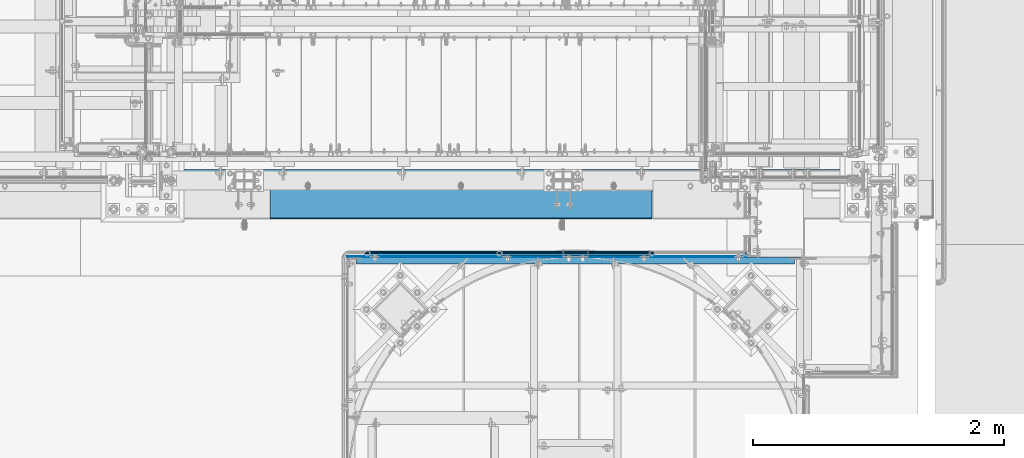
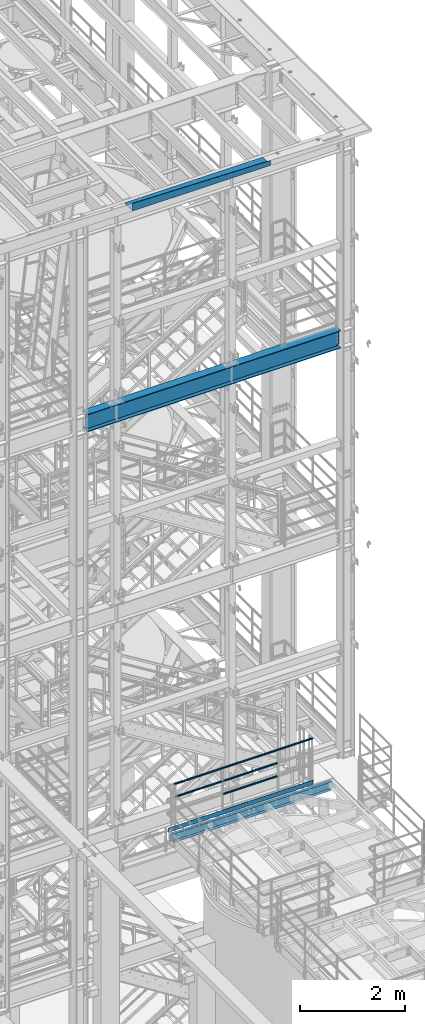
# One storey, part 944 of 1876: 8 beams, 4 elements without a shape of their own.
"""IFC2X3 building model written with IfcOpenShell, lengths in millimetres."""

from ifc_helpers import new_model, si_unit, frame, origin_with_axes, place, context, subcontext, project, spatial, faceted_brep, material, type_object, element, aggregate, save


model = new_model("IFC2X3")

# Units and contexts
model_context = context("Model", 3, precision=1e-05, world=origin_with_axes())
body_context = subcontext(model_context, "Body", "Model", "MODEL_VIEW")
ifc_project = project(units=[si_unit("LENGTHUNIT", "METRE", prefix="MILLI"), si_unit("AREAUNIT", "SQUARE_METRE"), si_unit("VOLUMEUNIT", "CUBIC_METRE"), si_unit("MASSUNIT", "GRAM", prefix="KILO"), si_unit("TIMEUNIT", "SECOND"), si_unit("PLANEANGLEUNIT", "RADIAN"), si_unit("SOLIDANGLEUNIT", "STERADIAN"), si_unit("THERMODYNAMICTEMPERATUREUNIT", "DEGREE_CELSIUS"), si_unit("LUMINOUSINTENSITYUNIT", "LUMEN")], contexts=[model_context])

# Site, building, storey
site_placement = place(None, origin_with_axes())
site = spatial("IfcSite", under=ifc_project, at=site_placement, CompositionType="ELEMENT")
building_placement = place(site_placement, origin_with_axes())
building = spatial("IfcBuilding", under=site, at=building_placement, Name="Undefined", CompositionType="ELEMENT")
storey_placement = place(building_placement, origin_with_axes())
storey = spatial("IfcBuildingStorey", under=building, at=storey_placement, Name="Undefined", CompositionType="ELEMENT", Elevation=0.0)

# Assembly, beams
assembly_1_placement = place(storey_placement, origin_with_axes())
assembly_1 = element("IfcElementAssembly", 1, at=assembly_1_placement, inside=storey, Name="HANDRAIL", AssemblyPlace="NOTDEFINED", PredefinedType="RIGID_FRAME")
ifc_material_1 = material()
beam_type_1 = type_object("IfcBeamType", Name="PIPE1-1/4STD", PredefinedType="NOTDEFINED")
beam_1_placement = place(assembly_1_placement, frame((4572.00474593762, -7694.13240429563, 8480.425), z_axis=(0.0, 0.0, 1.0), x_axis=(1.0, 0.0, 0.0)))
beam_1 = element("IfcBeam", 2, at=beam_1_placement, type_object=beam_type_1, material=ifc_material_1, Name="RAIL", ObjectType="PIPE1-1/4STD", context=body_context, shape_type="Brep", body=[
    faceted_brep([(1200.94245243742, -10.5409999999993, 18.2575475625836), (1200.94245243742, -10.5409999999993, 13.3999612267253), (1200.46603877327, -8.76300000000083, 15.1779612267255), (1198.118, 0.0, 17.5259999999998), (1198.118, 0.0, 21.0820000000003), (1200.46603877327, 8.76300000000083, 15.1779612267255), (1200.94245243742, 10.5409999999993, 13.3999612267253), (1200.94245243742, 10.5409999999993, 18.2575475625836), (1219.2, 21.0820000000003, 0.0), (1208.659, 18.2575475625836, 10.5409999999993), (1208.659, 18.2575475625836, -10.5409999999993), (1205.57941366414, 15.1779612267255, 8.76300000000083), (1207.92745243742, 17.5259999999998, 0.0), (1205.57941366414, 15.1779612267255, -8.76300000000083), (1200.94245243742, 10.5409999999993, -13.3999612267253), (1200.94245243742, 10.5409999999993, -18.2575475625836), (1200.46603877327, 8.76300000000083, -15.1779612267255), (1198.118, 0.0, -17.5259999999998), (1198.118, 0.0, -21.0820000000003), (1200.94245243742, -10.5409999999993, -13.3999612267253), (1200.94245243742, -10.5409999999993, -18.2575475625836), (1200.46603877327, -8.76300000000083, -15.1779612267255), (1219.2, -21.0820000000003, 0.0), (1208.659, -18.2575475625836, -10.5409999999993), (1208.659, -18.2575475625836, 10.5409999999993), (1205.57941366414, -15.1779612267255, -8.76300000000083), (1207.92745243742, -17.5259999999998, 0.0), (1205.57941366414, -15.1779612267255, 8.76300000000083), (10.5409999957128, -18.2575475672238, -10.5409999999993), (18.2575475625817, -10.5410000000011, -18.2575475625836), (9.09494701772928e-13, 21.0820000000003, 0.0), (10.5409999957128, 18.2575475579433, -10.5409999999993), (10.5409999999983, 18.2575475625836, 10.5410000000011), (18.2575475625817, 10.5409999999993, 18.2575475625836), (21.0819999999985, 1.81898940354586e-12, 21.0820000000003), (18.2575475625817, 10.5409999999993, -18.2575475625836), (21.0819999999985, 0.0, -21.0819999999985), (21.0819999999985, 0.0, -17.5259999999998), (18.2575475625817, -10.5409999999974, -13.3999612267271), (18.7339612267233, -8.76300000000083, -15.1779612267255), (18.7339612267251, 8.76299999999901, -15.1779612267255), (18.2575475625817, 10.5410000000011, -13.3999612267235), (13.6205863358573, 15.1779612267255, -8.76299999999901), (11.2725475625839, 17.5259999999998, 0.0), (13.6205863358573, 15.1779612267255, 8.76300000000083), (18.2575475625817, 10.5410000000011, 13.3999612267253), (18.7339612267251, 8.76299999999901, 15.1779612267273), (21.0819999999985, 1.81898940354586e-12, 17.5259999999998), (18.7339612267233, -8.76300000000083, 15.1779612267273), (18.2575475625817, -10.5409999999974, 13.3999612267289), (18.2575475625817, -10.5410000000011, 18.2575475625836), (10.5409999999983, -18.2575475625836, 10.5410000000011), (9.09494701772928e-13, -21.0820000000003, 0.0), (13.6205863358537, -15.1779612267255, 8.76300000000083), (11.2725475625793, -17.5259999999998, 0.0), (13.6205863358537, -15.1779612267255, -8.76299999999901)], [[[0, 1, 2, 3, 4]], [[4, 3, 5, 6, 7]], [[8, 9, 10]], [[7, 6, 11, 12, 13, 14, 15, 10, 9]], [[16, 17, 18, 15, 14]], [[19, 20, 18, 17, 21]], [[22, 23, 24]], [[24, 23, 20, 19, 25, 26, 27, 1, 0]], [[28, 29, 20, 23]], [[30, 31, 32]], [[33, 34, 4, 7]], [[32, 33, 7, 9]], [[30, 32, 9, 8]], [[31, 30, 8, 10]], [[35, 31, 10, 15]], [[36, 35, 15, 18]], [[29, 36, 18, 20]], [[37, 36, 29, 38, 39]], [[40, 41, 35, 36, 37]], [[32, 31, 35, 41, 42, 43, 44, 45, 33]], [[33, 45, 46, 47, 34]], [[34, 47, 48, 49, 50]], [[34, 50, 0, 4]], [[50, 51, 24, 0]], [[51, 52, 22, 24]], [[52, 28, 23, 22]], [[51, 28, 52]], [[50, 49, 53, 54, 55, 38, 29, 28, 51]], [[55, 54, 26, 25]], [[21, 39, 38, 55, 25, 19]], [[37, 39, 21, 17]], [[40, 37, 17, 16]], [[42, 41, 40, 16, 14, 13]], [[43, 42, 13, 12]], [[44, 43, 12, 11]], [[5, 46, 45, 44, 11, 6]], [[47, 46, 5, 3]], [[48, 47, 3, 2]], [[53, 49, 48, 2, 1, 27]], [[54, 53, 27, 26]]]),
])
beam_2_placement = place(assembly_1_placement, frame((5791.20474593762, -7694.13240429563, 8785.225), z_axis=(0.0, 0.0, -1.0), x_axis=(-1.0, 0.0, 0.0)))
beam_2 = element("IfcBeam", 3, at=beam_2_placement, type_object=beam_type_1, material=ifc_material_1, Name="RAIL", ObjectType="PIPE1-1/4STD", context=body_context, shape_type="Brep", body=[
    faceted_brep([(9.09494701772928e-13, 21.0820000000003, 0.0), (10.5409999957128, 18.2575475579433, -10.5409999999993), (10.5409999999983, 18.2575475625836, 10.5410000000011), (10.5409999999983, -18.2575475625836, 10.5410000000011), (10.5409999957128, -18.2575475672238, -10.5409999999993), (9.09494701772928e-13, -21.0820000000003, 0.0), (18.2575475625817, -10.5410000000011, 18.2575475625836), (18.2575475625817, -10.5409999999974, 13.3999612267289), (13.6205863358537, -15.1779612267255, 8.76300000000083), (11.2725475625793, -17.5259999999998, 0.0), (13.6205863358537, -15.1779612267255, -8.76299999999901), (18.2575475625817, -10.5409999999974, -13.3999612267271), (18.2575475625817, -10.5410000000011, -18.2575475625836), (21.0819999999985, 0.0, -17.5259999999998), (21.0819999999985, 0.0, -21.0819999999985), (18.7339612267233, -8.76300000000083, -15.1779612267255), (18.7339612267251, 8.76299999999901, -15.1779612267255), (18.2575475625817, 10.5410000000011, -13.3999612267235), (18.2575475625817, 10.5409999999993, -18.2575475625836), (13.6205863358573, 15.1779612267255, -8.76299999999901), (11.2725475625839, 17.5259999999998, 0.0), (13.6205863358573, 15.1779612267255, 8.76300000000083), (18.2575475625817, 10.5410000000011, 13.3999612267253), (18.2575475625817, 10.5409999999993, 18.2575475625836), (18.7339612267251, 8.76299999999901, 15.1779612267273), (21.0819999999985, 1.81898940354586e-12, 17.5259999999998), (21.0819999999985, 1.81898940354586e-12, 21.0820000000003), (18.7339612267233, -8.76300000000083, 15.1779612267273), (1219.2, 21.0820000000003, 0.0), (1208.659, 18.2575475625836, -10.5409999999993), (1200.94245243742, 10.5409999999993, -18.2575475625836), (1219.2, -21.0820000000003, 0.0), (1208.659, -18.2575475625836, -10.5409999999993), (1208.659, -18.2575475625836, 10.5409999999993), (1200.94245243742, -10.5409999999993, 18.2575475625836), (1200.94245243742, -10.5409999999993, -18.2575475625836), (1198.118, 0.0, -21.0820000000003), (1200.46603877327, 8.76300000000083, -15.1779612267255), (1198.118, 0.0, -17.5259999999998), (1200.94245243742, 10.5409999999993, -13.3999612267253), (1200.94245243742, -10.5409999999993, -13.3999612267253), (1200.46603877327, -8.76300000000083, -15.1779612267255), (1205.57941366414, -15.1779612267255, -8.76300000000083), (1207.92745243742, -17.5259999999998, 0.0), (1205.57941366414, -15.1779612267255, 8.76300000000083), (1200.94245243742, -10.5409999999993, 13.3999612267253), (1200.46603877327, -8.76300000000083, 15.1779612267255), (1198.118, 0.0, 17.5259999999998), (1198.118, 0.0, 21.0820000000003), (1200.94245243742, 10.5409999999993, 18.2575475625836), (1208.659, 18.2575475625836, 10.5409999999993), (1200.94245243742, 10.5409999999993, 13.3999612267253), (1205.57941366414, 15.1779612267255, 8.76300000000083), (1207.92745243742, 17.5259999999998, 0.0), (1205.57941366414, 15.1779612267255, -8.76300000000083), (1200.46603877327, 8.76300000000083, 15.1779612267255)], [[[0, 1, 2]], [[3, 4, 5]], [[6, 7, 8, 9, 10, 11, 12, 4, 3]], [[13, 14, 12, 11, 15]], [[16, 17, 18, 14, 13]], [[2, 1, 18, 17, 19, 20, 21, 22, 23]], [[23, 22, 24, 25, 26]], [[26, 25, 27, 7, 6]], [[1, 0, 28, 29]], [[18, 1, 29, 30]], [[31, 32, 33]], [[6, 3, 33, 34]], [[3, 5, 31, 33]], [[5, 4, 32, 31]], [[4, 12, 35, 32]], [[12, 14, 36, 35]], [[14, 18, 30, 36]], [[37, 38, 36, 30, 39]], [[40, 35, 36, 38, 41]], [[33, 32, 35, 40, 42, 43, 44, 45, 34]], [[34, 45, 46, 47, 48]], [[26, 6, 34, 48]], [[2, 23, 49, 50]], [[23, 26, 48, 49]], [[0, 2, 50, 28]], [[28, 50, 29]], [[49, 51, 52, 53, 54, 39, 30, 29, 50]], [[48, 47, 55, 51, 49]], [[25, 24, 55, 47]], [[55, 24, 22, 21, 52, 51]], [[21, 20, 53, 52]], [[20, 19, 54, 53]], [[19, 17, 16, 37, 39, 54]], [[16, 13, 38, 37]], [[13, 15, 41, 38]], [[41, 15, 11, 10, 42, 40]], [[10, 9, 43, 42]], [[9, 8, 44, 43]], [[8, 7, 27, 46, 45, 44]], [[27, 25, 47, 46]]]),
])
beam_3_placement = place(assembly_1_placement, frame((4572.00474593762, -7694.13240429563, 8785.225), z_axis=(0.0, 0.0, -1.0), x_axis=(-1.0, 0.0, 0.0)))
beam_3 = element("IfcBeam", 4, at=beam_3_placement, type_object=beam_type_1, material=ifc_material_1, Name="RAIL", ObjectType="PIPE1-1/4STD", context=body_context, shape_type="Brep", body=[
    faceted_brep([(9.09494701772928e-13, 21.0820000000003, 0.0), (10.5409999957128, 18.2575475579433, -10.5409999999993), (10.5409999999983, 18.2575475625836, 10.5410000000011), (10.5409999999983, -18.2575475625836, 10.5410000000011), (10.5409999957128, -18.2575475672238, -10.5409999999993), (9.09494701772928e-13, -21.0820000000003, 0.0), (18.2575475625817, -10.5410000000011, 18.2575475625836), (18.2575475625817, -10.5409999999974, 13.3999612267289), (13.6205863358537, -15.1779612267255, 8.76300000000083), (11.2725475625793, -17.5259999999998, 0.0), (13.6205863358537, -15.1779612267255, -8.76299999999901), (18.2575475625817, -10.5409999999974, -13.3999612267271), (18.2575475625817, -10.5410000000011, -18.2575475625836), (21.0819999999985, 0.0, -17.5259999999998), (21.0819999999985, 0.0, -21.0819999999985), (18.7339612267233, -8.76300000000083, -15.1779612267255), (18.7339612267251, 8.76299999999901, -15.1779612267255), (18.2575475625817, 10.5410000000011, -13.3999612267235), (18.2575475625817, 10.5409999999993, -18.2575475625836), (13.6205863358573, 15.1779612267255, -8.76299999999901), (11.2725475625839, 17.5259999999998, 0.0), (13.6205863358573, 15.1779612267255, 8.76300000000083), (18.2575475625817, 10.5410000000011, 13.3999612267253), (18.2575475625817, 10.5409999999993, 18.2575475625836), (18.7339612267251, 8.76299999999901, 15.1779612267273), (21.0819999999985, 1.81898940354586e-12, 17.5259999999998), (21.0819999999985, 1.81898940354586e-12, 21.0820000000003), (18.7339612267233, -8.76300000000083, 15.1779612267273), (1054.1, 21.0820000000003, 0.0), (1043.559, 18.2575475625836, -10.5409999999993), (1035.84245243742, 10.5409999999993, -18.2575475625836), (1054.1, -21.0820000000003, 0.0), (1043.559, -18.2575475625836, -10.5409999999993), (1043.559, -18.2575475625836, 10.5409999999993), (1035.84245243742, -10.5409999999993, 18.2575475625836), (1035.84245243742, -10.5409999999993, -18.2575475625836), (1033.018, 0.0, -21.0820000000003), (1035.36603877327, 8.76300000000083, -15.1779612267255), (1033.018, 0.0, -17.5259999999998), (1035.84245243742, 10.5409999999993, -13.3999612267253), (1035.84245243742, -10.5409999999993, -13.3999612267253), (1035.36603877327, -8.76300000000083, -15.1779612267255), (1040.47941366414, -15.1779612267255, -8.76300000000083), (1042.82745243742, -17.5259999999998, 0.0), (1040.47941366414, -15.1779612267255, 8.76300000000083), (1035.84245243742, -10.5409999999993, 13.3999612267253), (1035.36603877327, -8.76300000000083, 15.1779612267255), (1033.018, 0.0, 17.5259999999998), (1033.018, 0.0, 21.0820000000003), (1035.84245243742, 10.5409999999993, 18.2575475625836), (1043.559, 18.2575475625836, 10.5409999999993), (1035.84245243742, 10.5409999999993, 13.3999612267253), (1040.47941366414, 15.1779612267255, 8.76300000000083), (1042.82745243742, 17.5259999999998, 0.0), (1040.47941366414, 15.1779612267255, -8.76300000000083), (1035.36603877327, 8.76300000000083, 15.1779612267255)], [[[0, 1, 2]], [[3, 4, 5]], [[6, 7, 8, 9, 10, 11, 12, 4, 3]], [[13, 14, 12, 11, 15]], [[16, 17, 18, 14, 13]], [[2, 1, 18, 17, 19, 20, 21, 22, 23]], [[23, 22, 24, 25, 26]], [[26, 25, 27, 7, 6]], [[1, 0, 28, 29]], [[18, 1, 29, 30]], [[31, 32, 33]], [[6, 3, 33, 34]], [[3, 5, 31, 33]], [[5, 4, 32, 31]], [[4, 12, 35, 32]], [[12, 14, 36, 35]], [[14, 18, 30, 36]], [[37, 38, 36, 30, 39]], [[40, 35, 36, 38, 41]], [[33, 32, 35, 40, 42, 43, 44, 45, 34]], [[34, 45, 46, 47, 48]], [[26, 6, 34, 48]], [[2, 23, 49, 50]], [[23, 26, 48, 49]], [[0, 2, 50, 28]], [[28, 50, 29]], [[49, 51, 52, 53, 54, 39, 30, 29, 50]], [[48, 47, 55, 51, 49]], [[25, 24, 55, 47]], [[55, 24, 22, 21, 52, 51]], [[21, 20, 53, 52]], [[20, 19, 54, 53]], [[19, 17, 16, 37, 39, 54]], [[16, 13, 38, 37]], [[13, 15, 41, 38]], [[41, 15, 11, 10, 42, 40]], [[10, 9, 43, 42]], [[9, 8, 44, 43]], [[8, 7, 27, 46, 45, 44]], [[27, 25, 47, 46]]]),
])
beam_4_placement = place(assembly_1_placement, frame((6565.9, -7694.13240429563, 9090.025), z_axis=(0.0, 0.0, -1.0), x_axis=(-1.0, 0.0, 0.0)))
beam_4 = element("IfcBeam", 5, at=beam_4_placement, type_object=beam_type_1, material=ifc_material_1, Name="HANDRAIL", ObjectType="PIPE1-1/4STD", context=body_context, shape_type="Brep", body=[
    faceted_brep([(3.56058182859306, -17.5259999999998, 0.0), (5.90862060186646, -15.1779612267264, 8.76300000000083), (3069.07725406238, -15.1779612267264, 8.76300000000083), (3069.07725406238, -17.5259999999998, 0.0), (12.323581828593, -8.76299999999992, 15.1779612267255), (3069.07725406238, -8.76299999999992, 15.1779612267255), (21.0865818285929, 0.0, 17.5259999999998), (3069.07725406238, 0.0, 17.5259999999998), (29.8495818285928, 8.76299999999992, 15.1779612267255), (3069.07725406238, 8.76299999999992, 15.1779612267255), (36.2645430553193, 15.1779612267264, 8.76300000000083), (3069.07725406238, 15.1779612267264, 8.76300000000083), (38.6125818285927, 17.5259999999998, 0.0), (3069.07725406238, 17.5259999999998, 0.0), (36.2645430553193, 15.1779612267264, -8.76300000000083), (3069.07725406238, 15.1779612267264, -8.76300000000083), (29.8495818285928, 8.76299999999992, -15.1779612267255), (3069.07725406238, 8.76299999999992, -15.1779612267255), (21.0865818285929, 0.0, -17.5259999999998), (3069.07725406238, 0.0, -17.5259999999998), (12.323581828593, -8.76299999999992, -15.1779612267255), (3069.07725406238, -8.76299999999992, -15.1779612267255), (5.90862060186646, -15.1779612267264, -8.76300000000083), (3069.07725406238, -15.1779612267264, -8.76300000000083), (0.0045818285925634, -21.0820000000003, 0.0), (2.82903426600933, -18.2575475625836, -10.5409999999993), (3069.07725406238, -18.2575475625836, -10.5409999999993), (3069.07725406238, -21.0820000000003, 0.0), (10.5455818285927, -10.5410000000002, -18.2575475625836), (3069.07725406238, -10.5410000000002, -18.2575475625836), (21.0865818285929, 0.0, -21.0820000000003), (3069.07725406238, 0.0, -21.0820000000003), (31.6275818285931, 10.5410000000002, -18.2575475625836), (3069.07725406238, 10.5410000000002, -18.2575475625836), (39.3441293911765, 18.2575475625836, -10.5409999999993), (3069.07725406238, 18.2575475625836, -10.5409999999993), (42.1685818285932, 21.0820000000003, 0.0), (3069.07725406238, 21.0820000000003, 0.0), (39.3441293911765, 18.2575475625836, 10.5409999999993), (3069.07725406238, 18.2575475625836, 10.5409999999993), (31.6275818285931, 10.5410000000002, 18.2575475625836), (3069.07725406238, 10.5410000000002, 18.2575475625836), (21.0865818285929, 0.0, 21.0820000000003), (3069.07725406238, 0.0, 21.0820000000003), (10.5455818285927, -10.5410000000002, 18.2575475625836), (3069.07725406238, -10.5410000000002, 18.2575475625836), (2.82903426600933, -18.2575475625836, 10.5409999999993), (3069.07725406238, -18.2575475625836, 10.5409999999993)], [[[0, 1, 2, 3]], [[1, 4, 5, 2]], [[4, 6, 7, 5]], [[6, 8, 9, 7]], [[8, 10, 11, 9]], [[10, 12, 13, 11]], [[12, 14, 15, 13]], [[14, 16, 17, 15]], [[16, 18, 19, 17]], [[18, 20, 21, 19]], [[20, 22, 23, 21]], [[22, 0, 3, 23]], [[24, 25, 26, 27]], [[25, 28, 29, 26]], [[28, 30, 31, 29]], [[30, 32, 33, 31]], [[32, 34, 35, 33]], [[34, 36, 37, 35]], [[36, 38, 39, 37]], [[38, 40, 41, 39]], [[40, 42, 43, 41]], [[42, 44, 45, 43]], [[44, 46, 47, 45]], [[46, 24, 27, 47]], [[29, 31, 33, 35, 37, 39, 41, 43, 45, 47, 27, 26], [5, 7, 9, 11, 13, 15, 17, 19, 21, 23, 3, 2]], [[46, 44, 42, 40, 38, 36, 34, 32, 30, 28, 25, 24], [22, 20, 18, 16, 14, 12, 10, 8, 6, 4, 1, 0]]]),
])
ifc_material_2 = material(Name="STEEL/A36")
beam_type_2 = type_object("IfcBeamType", PredefinedType="NOTDEFINED")
beam_5_placement = place(assembly_1_placement, frame((3359.15474593762, -7718.38940429563, 8080.375), z_axis=(0.0, 0.0, 1.0), x_axis=(1.0, 0.0, 0.0)))
beam_5 = element("IfcBeam", 6, at=beam_5_placement, type_object=beam_type_2, material=ifc_material_2, Name="PLATE", context=body_context, shape_type="Brep", body=[
    faceted_brep([(0.0, 3.17500000000018, -50.8000000000002), (0.0, 3.17500000000018, 50.8000000000002), (3186.1125, 3.17500000000018, 50.8000000000002), (3186.1125, 3.17500000000018, -50.8000000000002), (0.0, -3.17500000000018, 50.8000000000002), (3186.1125, -3.17500000000018, 50.8000000000002), (0.0, -3.17500000000018, -50.8000000000002), (3186.1125, -3.17500000000018, -50.8000000000002)], [[[0, 1, 2, 3]], [[1, 4, 5, 2]], [[4, 6, 7, 5]], [[6, 0, 3, 7]], [[5, 7, 3, 2]], [[6, 4, 1, 0]]]),
])
aggregate(assembly_1, [beam_5, beam_1, beam_2, beam_3, beam_4])

# Assembly, beam
assembly_2_placement = place(storey_placement, origin_with_axes())
assembly_2 = element("IfcElementAssembly", 7, at=assembly_2_placement, inside=storey, Name="BEAM", AssemblyPlace="NOTDEFINED", PredefinedType="RIGID_FRAME")
beam_type_3 = type_object("IfcBeamType", Name="C8X11.5", PredefinedType="NOTDEFINED")
beam_6_placement = place(assembly_2_placement, frame((3365.50333884985, -7750.13940429563, 7896.225), z_axis=(0.0, 0.0, 1.0), x_axis=(1.0, 0.0, 0.0)))
beam_6 = element("IfcBeam", 8, at=beam_6_placement, type_object=beam_type_3, material=ifc_material_2, Name="BEAM", ObjectType="C8X11.5", context=body_context, shape_type="Brep", body=[
    faceted_brep([(3562.34713699756, -28.5749999999998, -96.8355949999996), (3562.34713699756, -28.5749999999998, -101.6), (3562.34713699756, 28.5749999999998, -101.6), (3562.34713699756, 28.5749999999998, -88.8999998092659), (3562.34713699756, 19.0576241940826, -88.8999998092659), (3562.45210003221, 22.2250000000004, -88.3723149999996), (3563.31386692015, 28.5749999999998, -84.0399202912204), (3563.31386692015, 22.2250000000004, -84.0399202912204), (3566.06688082063, 28.5749999999998, -79.9197438230667), (3566.06688082063, 22.2250000000004, -79.9197438230667), (3570.18705728878, 28.5749999999998, -77.1667299225883), (3570.18705728878, 22.2250000000004, -77.1667299225883), (3575.04713680683, 28.5749999999998, -76.2000000000007), (3575.04713680683, 22.2250000000004, -76.2000000000007), (3613.14713699757, 22.2250000000004, -76.2000000000007), (3613.14713699757, 28.5749999999998, -76.2000000000007), (69.8500000000013, 28.5750000000007, 101.6), (69.8500000000013, -28.5750000000007, 101.6), (3562.34713699756, -28.5749999999998, 101.6), (3562.34713699756, 28.5749999999998, 101.6), (69.8500000000013, 19.0576241940817, -88.8999998092659), (69.8500000000013, 28.5750000000007, -88.8999998092659), (69.8500000000013, 28.5750000000007, -101.6), (69.8500000000013, -28.5750000000007, -101.6), (69.8500000000013, -28.5750000000007, -96.8355949999996), (69.7450369653598, 22.2250000000004, -88.3723149999996), (68.8832700774137, 22.2250000000004, -84.0399202912204), (68.8832700774137, 28.5750000000007, -84.0399202912204), (66.1302561769353, 22.2250000000004, -79.9197438230667), (66.1302561769353, 28.5750000000007, -79.9197438230667), (62.0100797087816, 22.2250000000004, -77.1667299225883), (62.0100797087816, 28.5750000000007, -77.1667299225883), (57.1500001907361, 22.2250000000004, -76.2000000000007), (57.1500001907361, 28.5750000000007, -76.2000000000007), (19.0499999999993, 22.2250000000004, -76.2000000000007), (19.0499999999993, 28.5750000000007, -76.2000000000007), (19.0499999999993, 22.2250000000004, 76.1999999999989), (19.0499999999993, 28.5750000000007, 76.1999999999989), (57.1500001907361, 22.2250000000004, 76.1999999999989), (57.1500001907361, 28.5750000000007, 76.1999999999989), (62.0100797087816, 22.2250000000004, 77.1667299225865), (62.0100797087816, 28.5750000000007, 77.1667299225865), (66.1302561769353, 22.2250000000004, 79.9197438230649), (66.1302561769353, 28.5750000000007, 79.9197438230649), (68.8832700774137, 22.2250000000004, 84.0399202912186), (68.8832700774137, 28.5750000000007, 84.0399202912186), (69.8500000000013, 19.0576241940926, 88.899999809264), (69.8500000000013, 28.5750000000007, 88.899999809264), (69.7450369653607, 22.2250000000004, 88.3723149999996), (69.8500000000013, -28.5750000000007, 96.8355949999996), (3562.34713699756, -28.5749999999998, 96.8355949999996), (3562.34713699756, 19.0576241940935, 88.899999809264), (3562.34713699756, 28.5749999999998, 88.899999809264), (3562.4521000322, 22.2250000000004, 88.3723149999996), (3563.31386692015, 22.2250000000004, 84.0399202912186), (3563.31386692015, 28.5749999999998, 84.0399202912186), (3566.06688082063, 22.2250000000004, 79.9197438230649), (3566.06688082063, 28.5749999999998, 79.9197438230649), (3570.18705728878, 22.2250000000004, 77.1667299225865), (3570.18705728878, 28.5749999999998, 77.1667299225865), (3575.04713680683, 22.2250000000004, 76.1999999999989), (3575.04713680683, 28.5749999999998, 76.1999999999989), (3613.14713699757, 22.2250000000004, 76.1999999999989), (3613.14713699757, 28.5749999999998, 76.1999999999989)], [[[0, 1, 2, 3, 4]], [[5, 4, 3, 6, 7]], [[7, 6, 8, 9]], [[9, 8, 10, 11]], [[11, 10, 12, 13]], [[14, 13, 12, 15]], [[16, 17, 18, 19]], [[20, 21, 22, 23, 24]], [[25, 26, 27, 21, 20]], [[28, 29, 27, 26]], [[30, 31, 29, 28]], [[32, 33, 31, 30]], [[34, 35, 33, 32]], [[36, 37, 35, 34]], [[38, 39, 37, 36]], [[40, 41, 39, 38]], [[42, 43, 41, 40]], [[44, 45, 43, 42]], [[46, 47, 45, 44, 48]], [[17, 16, 47, 46, 49]], [[17, 49, 50, 18]], [[18, 50, 51, 52, 19]], [[49, 46, 48, 53, 51, 50]], [[54, 55, 52, 51, 53]], [[56, 57, 55, 54]], [[58, 59, 57, 56]], [[60, 61, 59, 58]], [[62, 63, 61, 60]], [[63, 62, 14, 15]], [[10, 8, 6, 3, 2, 22, 21, 27, 29, 31, 33, 35, 37, 39, 41, 43, 45, 47, 16, 19, 52, 55, 57, 59, 61, 63, 15, 12]], [[23, 22, 2, 1]], [[24, 23, 1, 0]], [[25, 20, 24, 0, 4, 5]], [[62, 60, 58, 56, 54, 53, 48, 44, 42, 40, 38, 36, 34, 32, 30, 28, 26, 25, 5, 7, 9, 11, 13, 14]]]),
])
aggregate(assembly_2, [beam_6])

assembly_3_placement = place(storey_placement, origin_with_axes())
assembly_3 = element("IfcElementAssembly", 9, at=assembly_3_placement, inside=storey, Name="BENT PLATE", AssemblyPlace="NOTDEFINED", PredefinedType="RIGID_FRAME")
beam_type_4 = type_object("IfcBeamType", PredefinedType="NOTDEFINED")
beam_7_placement = place(assembly_3_placement, frame((4267.2, -7111.99997714219, 22558.3750000001), z_axis=(1.0, 0.0, 0.0), x_axis=(0.0, -0.999999999968684, -7.91400000071008e-06)))
beam_7 = element("IfcBeam", 10, at=beam_7_placement, type_object=beam_type_4, material=ifc_material_2, Name="BENT PLATE", context=body_context, shape_type="Brep", body=[
    faceted_brep([(9.877112461254e-10, -3.17499999999563, 1524.0), (9.877112461254e-10, -3.17499999999563, -1524.0), (298.449951181137, -3.17499990713986, -1524.0), (298.449951181137, -3.17499990713986, 1524.0), (-9.88620740827173e-10, 3.17500000000291, 1524.0), (-9.88620740827173e-10, 3.17500000000291, -1524.0), (304.799984389461, 3.1750000948341, 1524.0), (304.799984389461, 3.1750000948341, -1524.0), (304.799391923075, -110.115017685177, 1524.0), (304.799059744488, -173.633419539718, -1524.0), (298.449059744571, -173.633386331483, -1524.0), (298.449391923224, -110.114971971529, 1524.0)], [[[0, 1, 2, 3]], [[1, 0, 4, 5]], [[5, 4, 6, 7]], [[7, 6, 8, 9]], [[2, 1, 5, 7, 9, 10]], [[3, 2, 10, 11]], [[6, 4, 0, 3, 11, 8]], [[10, 9, 8, 11]]]),
])
aggregate(assembly_3, [beam_7])

assembly_4_placement = place(storey_placement, origin_with_axes())
assembly_4 = element("IfcElementAssembly", 11, at=assembly_4_placement, inside=storey, Name="BEAM", AssemblyPlace="NOTDEFINED", PredefinedType="RIGID_FRAME")
ifc_material_3 = material(Name="STEEL/A992")
beam_type_5 = type_object("IfcBeamType", Name="W16X45", PredefinedType="NOTDEFINED")
beam_8_placement = place(assembly_4_placement, frame((1727.2, -7112.0, 17778.4125), z_axis=(0.0, 0.0, 1.0), x_axis=(1.0, 0.0, 0.0)))
beam_8 = element("IfcBeam", 12, at=beam_8_placement, type_object=beam_type_5, material=ifc_material_3, Name="BEAM", ObjectType="W16X45", context=body_context, shape_type="Brep", body=[
    faceted_brep([(5748.3375, 4.76249999999982, 161.924999999999), (5738.81249970572, -4.76249999999982, 161.924999999999), (5738.81249970572, -4.76249999999982, -161.924999999999), (5748.3375, 4.76249999999982, -161.924999999999), (144.4625, 88.8999999999996, 190.5), (152.711099599373, 88.8999999999996, 204.787499999999), (5740.08890040063, 88.8999999999996, 204.787499999999), (5748.3375, 88.8999999999996, 190.5), (144.4625, 4.76249999999982, 190.5), (5748.3375, 4.76249999999982, 190.5), (152.711120260645, -88.8999999999996, -190.5), (144.4625, -88.8999999999996, -204.787499999999), (5748.3375, -88.8999999999996, -204.787499999999), (5740.08887973935, -88.8999999999996, -190.5), (144.4625, 88.8999999999996, -204.787499999999), (5748.3375, 88.8999999999996, -204.787499999999), (152.711120260645, 88.8999999999996, -190.5), (5740.08887973935, 88.8999999999996, -190.5), (152.711120260645, 4.76249999999982, -190.5), (5740.08887973935, 4.76249999999982, -190.5), (5696.31330732956, -4.76249999999982, -163.290718362852), (5696.31330732956, 4.76249999999982, -163.290718362852), (5701.22775003691, 4.76249999999982, -161.924999999999), (5701.22775003691, -4.76249999999982, -161.924999999999), (5692.80815489359, -4.76249999999982, -166.996233194965), (5692.80815489359, 4.76249999999982, -166.996233194965), (5691.71744784461, -4.76249999999982, -171.978932453771), (5691.71744784461, 4.76249999999982, -171.978932453771), (5693.35396281357, -4.76249999999982, -176.80995227641), (5693.35396281357, 4.76249999999982, -176.80995227641), (5697.24840454932, -4.76249999999982, -180.103925156887), (5697.24840454932, 4.76249999999982, -180.103925156887), (5718.99349932861, -4.76249999999982, -190.102999496459), (5718.99349932861, 4.76249999999982, -190.102999496459), (5739.85968949887, -4.76249999999982, -190.102999496459), (5739.85968949887, 4.76249999999982, -190.102999496459), (5740.08887973935, -4.76249999999982, -190.5), (152.711120260645, -4.76249999999982, -190.5), (152.940310501126, -4.76249999999982, -190.102999496459), (152.940310501126, 4.76249999999982, -190.102999496459), (173.806500671387, -4.76249999999982, -190.102999496459), (173.806500671387, 4.76249999999982, -190.102999496459), (195.551595450686, -4.76249999999982, -180.103925156884), (195.551595450686, 4.76249999999982, -180.103925156884), (199.446037186428, -4.76249999999982, -176.80995227641), (199.446037186428, 4.76249999999982, -176.80995227641), (201.082552155395, -4.76249999999982, -171.978932453767), (201.082552155395, 4.76249999999982, -171.978932453767), (199.991845106413, -4.76249999999982, -166.996233194965), (199.991845106413, 4.76249999999982, -166.996233194965), (196.486692670442, -4.76249999999982, -163.290718362852), (196.486692670442, 4.76249999999982, -163.290718362852), (191.572249963099, -4.76249999999982, -161.924999999999), (191.572249963099, 4.76249999999982, -161.924999999999), (153.987500294277, -4.76249999999982, -161.924999999996), (144.4625, 4.76249999999982, -161.924999999996), (153.987500294277, -4.7625002942832, 161.925000000003), (144.4625, 4.76249999999982, 161.925000000003), (190.80324988243, -4.76249999999982, 161.924999999999), (190.80324988243, 4.76249999999982, 161.924999999999), (195.717692628333, -4.76249999999982, 163.290718386077), (195.717692628333, 4.76249999999982, 163.290718386077), (199.22284506784, -4.76249999999982, 166.996233274545), (199.22284506784, 4.76249999999982, 166.996233274545), (200.313552067229, -4.76249999999982, 171.978932588601), (200.313552067229, 4.76249999999982, 171.978932588601), (198.677037004441, -4.76249999999982, 176.80995242525), (198.677037004441, 4.76249999999982, 176.80995242525), (194.782595165536, -4.76249999999982, 180.103925250914), (194.782595165536, 4.76249999999982, 180.103925250914), (173.037499237061, -4.76249999999982, 190.102999496463), (173.037499237061, 4.76249999999982, 190.102999496463), (144.4625, -4.76249999999982, 190.102999496463), (144.4625, 4.76249999999982, 190.102999496463), (144.4625, -4.76249999999982, 190.5), (152.711099599373, -88.8999999999996, 204.787499999999), (144.4625, -88.8999999999996, 190.5), (5748.3375, -4.76249999999982, 190.5), (5748.3375, -88.8999999999996, 190.5), (5740.08890040063, -88.8999999999996, 204.787499999999), (5748.3375, -4.76249999999982, 190.102999496459), (5748.3375, 4.76249999999982, 190.102999496459), (5719.76250076294, -4.76249999999982, 190.102999496459), (5719.76250076294, 4.76249999999982, 190.102999496459), (5698.01740483447, -4.76249999999982, 180.103925250914), (5698.01740483447, 4.76249999999982, 180.103925250914), (5694.12296299556, -4.76249999999982, 176.80995242525), (5694.12296299556, 4.76249999999982, 176.80995242525), (5692.48644793277, -4.76249999999982, 171.978932588601), (5692.48644793277, 4.76249999999982, 171.978932588601), (5693.57715493216, -4.76249999999982, 166.996233274542), (5693.57715493216, 4.76249999999982, 166.996233274542), (5697.08230737167, -4.76249999999982, 163.290718386077), (5697.08230737167, 4.76249999999982, 163.290718386077), (5701.99675011757, -4.76249999999982, 161.924999999999), (5701.99675011757, 4.76249999999982, 161.924999999999)], [[[0, 1, 2, 3]], [[4, 5, 6, 7]], [[8, 4, 7, 9]], [[10, 11, 12, 13]], [[11, 14, 15, 12]], [[14, 16, 17, 15]], [[16, 18, 19, 17]], [[20, 21, 22, 23]], [[24, 25, 21, 20]], [[26, 27, 25, 24]], [[28, 29, 27, 26]], [[30, 31, 29, 28]], [[32, 33, 31, 30]], [[33, 32, 34, 35]], [[12, 15, 17, 19, 35, 34, 36, 13]], [[37, 10, 13, 36]], [[38, 39, 18, 16, 14, 11, 10, 37]], [[40, 41, 39, 38]], [[42, 43, 41, 40]], [[44, 45, 43, 42]], [[46, 47, 45, 44]], [[48, 49, 47, 46]], [[50, 51, 49, 48]], [[52, 53, 51, 50]], [[53, 52, 54, 55]], [[56, 57, 55, 54]], [[58, 59, 57, 56]], [[60, 61, 59, 58]], [[62, 63, 61, 60]], [[64, 65, 63, 62]], [[66, 67, 65, 64]], [[68, 69, 67, 66]], [[70, 71, 69, 68]], [[71, 70, 72, 73]], [[73, 72, 74, 8]], [[75, 5, 4, 8, 74, 76]], [[76, 74, 77, 78]], [[75, 76, 78, 79]], [[5, 75, 79, 6]], [[78, 77, 9, 7, 6, 79]], [[80, 81, 9, 77]], [[82, 83, 81, 80]], [[84, 85, 83, 82]], [[86, 87, 85, 84]], [[88, 89, 87, 86]], [[90, 91, 89, 88]], [[92, 93, 91, 90]], [[94, 95, 93, 92]], [[22, 21, 25, 27, 29, 31, 33, 35, 19, 18, 39, 41, 43, 45, 47, 49, 51, 53, 55, 57, 59, 61, 63, 65, 67, 69, 71, 73, 8, 9, 81, 83, 85, 87, 89, 91, 93, 95, 0, 3]], [[23, 22, 3, 2]], [[94, 92, 90, 88, 86, 84, 82, 80, 77, 74, 72, 70, 68, 66, 64, 62, 60, 58, 56, 54, 52, 50, 48, 46, 44, 42, 40, 38, 37, 36, 34, 32, 30, 28, 26, 24, 20, 23, 2, 1]], [[95, 94, 1, 0]]]),
])
aggregate(assembly_4, [beam_8])

save(model, "model.ifc")
